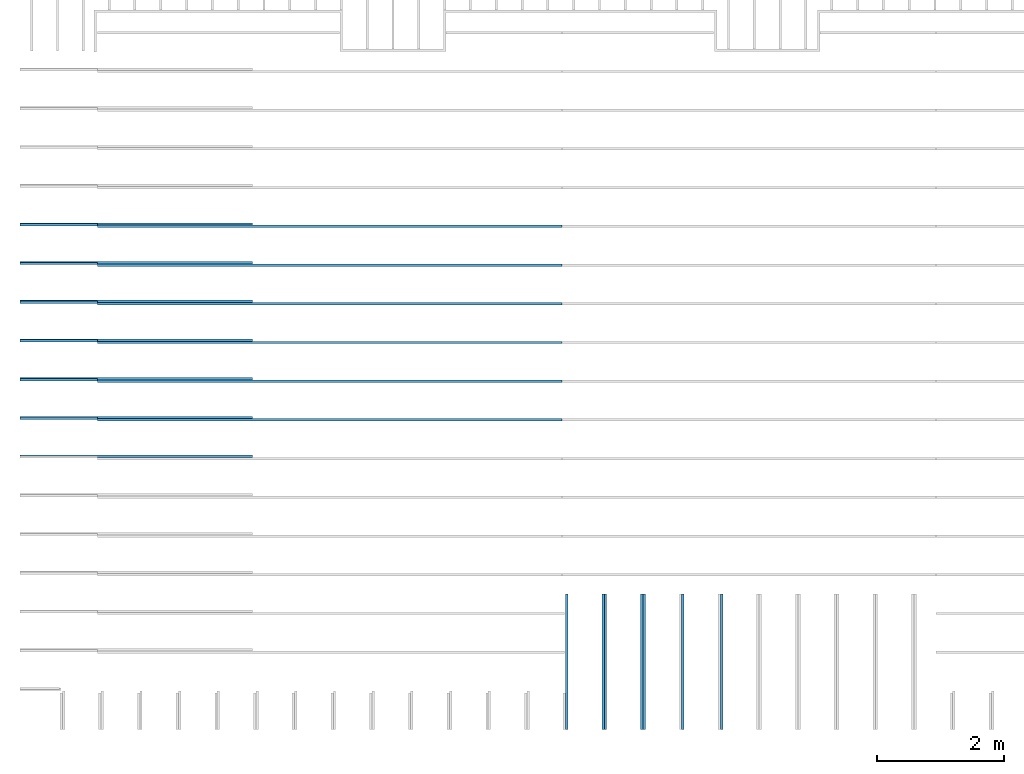
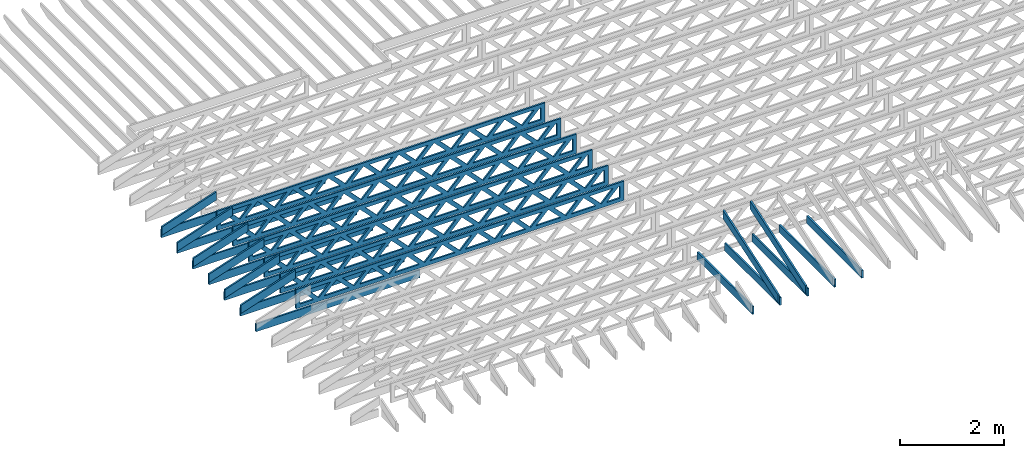
# One storey, part 2 of 17: 26 beams, 5 elements without a shape of their own.
"""IFC4 building model written with IfcOpenShell, lengths in feet."""

from ifc_helpers import new_model, entity, si_unit, converted_unit, derived_unit, direction, frame, frame_2d, origin, origin_2d_with_axis, place, context, subcontext, project, spatial, rectangle, extrude, clip, halfspace, source, transform, mapped, material, material_profile, profile_set, profile_usage, type_object, type_shapes, element, aggregate, save


model = new_model("IFC4")

# Units and contexts
model_context = context("Model", 3, precision=0.0001, world=origin(), true_north=direction((6.12303176911189e-17, 1.0)))
body_context = subcontext(model_context, "Body", "Model", "MODEL_VIEW")
ifc_project = project(units=[converted_unit("LENGTHUNIT", "FOOT", entity("IfcRatioMeasure", 0.3048), si_unit("LENGTHUNIT", "METRE"), dimensions=[1, 0, 0, 0, 0, 0, 0]), converted_unit("AREAUNIT", "SQUARE FOOT", entity("IfcRatioMeasure", 0.09290304), si_unit("AREAUNIT", "SQUARE_METRE"), dimensions=[2, 0, 0, 0, 0, 0, 0]), converted_unit("VOLUMEUNIT", "CUBIC FOOT", entity("IfcRatioMeasure", 0.028316846592), si_unit("VOLUMEUNIT", "CUBIC_METRE"), dimensions=[3, 0, 0, 0, 0, 0, 0]), converted_unit("PLANEANGLEUNIT", "DEGREE", entity("IfcRatioMeasure", 0.0174532925199433), si_unit("PLANEANGLEUNIT", "RADIAN"), dimensions=[0, 0, 0, 0, 0, 0, 0]), si_unit("MASSUNIT", "GRAM", prefix="KILO"), derived_unit("MASSDENSITYUNIT", [(si_unit("MASSUNIT", "GRAM", prefix="KILO"), 1), (si_unit("LENGTHUNIT", "METRE"), -3)]), derived_unit("MOMENTOFINERTIAUNIT", [(si_unit("LENGTHUNIT", "METRE"), 4)]), si_unit("TIMEUNIT", "SECOND"), si_unit("FREQUENCYUNIT", "HERTZ"), si_unit("THERMODYNAMICTEMPERATUREUNIT", "DEGREE_CELSIUS"), derived_unit("THERMALTRANSMITTANCEUNIT", [(si_unit("MASSUNIT", "GRAM", prefix="KILO"), 1), (si_unit("THERMODYNAMICTEMPERATUREUNIT", "KELVIN"), -1), (si_unit("TIMEUNIT", "SECOND"), -3)]), derived_unit("VOLUMETRICFLOWRATEUNIT", [(si_unit("LENGTHUNIT", "METRE"), 3), (si_unit("TIMEUNIT", "SECOND"), -1)]), si_unit("ELECTRICCURRENTUNIT", "AMPERE"), si_unit("ELECTRICVOLTAGEUNIT", "VOLT"), si_unit("POWERUNIT", "WATT"), si_unit("FORCEUNIT", "NEWTON"), si_unit("ILLUMINANCEUNIT", "LUX"), si_unit("LUMINOUSFLUXUNIT", "LUMEN"), si_unit("LUMINOUSINTENSITYUNIT", "CANDELA"), derived_unit("USERDEFINED", [(si_unit("MASSUNIT", "GRAM", prefix="KILO"), -1), (si_unit("LENGTHUNIT", "METRE"), -2), (si_unit("TIMEUNIT", "SECOND"), 3), (si_unit("LUMINOUSFLUXUNIT", "LUMEN"), 1)]), derived_unit("LINEARVELOCITYUNIT", [(si_unit("LENGTHUNIT", "METRE"), 1), (si_unit("TIMEUNIT", "SECOND"), -1)]), si_unit("PRESSUREUNIT", "PASCAL"), derived_unit("USERDEFINED", [(si_unit("LENGTHUNIT", "METRE"), -2), (si_unit("MASSUNIT", "GRAM", prefix="KILO"), 1), (si_unit("TIMEUNIT", "SECOND"), -2)]), derived_unit("LINEARFORCEUNIT", [(si_unit("MASSUNIT", "GRAM", prefix="KILO"), 1), (si_unit("LENGTHUNIT", "METRE"), 1), (si_unit("TIMEUNIT", "SECOND"), -2), (si_unit("LENGTHUNIT", "METRE"), -1)]), derived_unit("PLANARFORCEUNIT", [(si_unit("MASSUNIT", "GRAM", prefix="KILO"), 1), (si_unit("LENGTHUNIT", "METRE"), 1), (si_unit("TIMEUNIT", "SECOND"), -2), (si_unit("LENGTHUNIT", "METRE"), -2)])], contexts=[model_context])

# Site, building, storey
site_placement = place(None, origin())
site = spatial("IfcSite", under=ifc_project, at=site_placement, CompositionType="ELEMENT")
building_placement = place(site_placement, origin())
building = spatial("IfcBuilding", under=site, at=building_placement, CompositionType="ELEMENT")
storey_placement = place(building_placement, frame((0.0, 0.0, 30.4375000000082)))
storey = spatial("IfcBuildingStorey", under=building, at=storey_placement, Name="ROOF", CompositionType="ELEMENT", Elevation=30.4375000000082)

# Assembly, beams
assembly_1_placement = place(storey_placement, origin())
assembly_1 = element("IfcElementAssembly", 1, at=assembly_1_placement, inside=storey, Name="Structural Beam System:Structural Framing System", ObjectType="Structural Beam System:Structural Framing System", AssemblyPlace="NOTDEFINED", PredefinedType="BEAM_GRID")
ifc_material_1 = material(Name="WOOD TRUSS", Category="Materials")
ifc_material_profile_1 = material_profile(ifc_material_1, rectangle(XDim=1.73473973950632, YDim=0.125, at=origin_2d_with_axis()))
ifc_material_profile_2 = material_profile(ifc_material_1, rectangle(XDim=1.73473973950633, YDim=0.125, at=frame_2d((-1.11022302462516e-16, 0.0), x_axis=(1.0, 0.0))))
ifc_material_profile_3 = material_profile(ifc_material_1, rectangle(XDim=1.73473973950632, YDim=0.125, at=origin_2d_with_axis()))
ifc_material_profile_4 = material_profile(ifc_material_1, rectangle(XDim=1.73473973950633, YDim=0.125, at=origin_2d_with_axis()))
ifc_material_profile_5 = material_profile(ifc_material_1, rectangle(XDim=1.73473973950632, YDim=0.125, at=frame_2d((-5.55111512312578e-17, 0.0), x_axis=(1.0, 0.0))))
ifc_material_profile_6 = material_profile(ifc_material_1, rectangle(XDim=1.73473973950633, YDim=0.125, at=frame_2d((-2.77555756156289e-16, 0.0), x_axis=(1.0, 0.0))))
ifc_material_profile_7 = material_profile(ifc_material_1, rectangle(XDim=1.73473973950632, YDim=0.125, at=frame_2d((-4.9960036108132e-16, 0.0), x_axis=(1.0, 0.0))))
ifc_material_profile_8 = material_profile(ifc_material_1, rectangle(XDim=1.73473973950633, YDim=0.125, at=frame_2d((4.44089209850063e-16, 0.0), x_axis=(1.0, 0.0))))
ifc_material_profile_9 = material_profile(ifc_material_1, rectangle(XDim=1.73473973950632, YDim=0.125, at=origin_2d_with_axis()))
ifc_material_profile_10 = material_profile(ifc_material_1, rectangle(XDim=1.73473973950633, YDim=0.125, at=frame_2d((-4.9960036108132e-16, 0.0), x_axis=(1.0, 0.0))))
ifc_material_profile_11 = material_profile(ifc_material_1, rectangle(XDim=0.291666666666664, YDim=0.125, at=frame_2d((-2.77555756156289e-17, 0.0), x_axis=(1.0, 0.0))))
ifc_material_profile_12 = material_profile(ifc_material_1, rectangle(XDim=0.291666666666628, YDim=0.124999999999995, at=frame_2d((-5.55111512312578e-17, 0.0), x_axis=(1.0, 0.0))))
ifc_material_profile_13 = material_profile(ifc_material_1, rectangle(XDim=0.916666666666666, YDim=0.125000000000003, at=frame_2d((-2.77555756156289e-17, 0.0), x_axis=(1.0, 0.0))))
ifc_material_profile_14 = material_profile(ifc_material_1, rectangle(XDim=0.916666666666651, YDim=0.125, at=frame_2d((-2.77555756156289e-17, 0.0), x_axis=(1.0, 0.0))))
ifc_profile_set_1 = profile_set([ifc_material_profile_1, ifc_material_profile_2, ifc_material_profile_3, ifc_material_profile_4, ifc_material_profile_5, ifc_material_profile_6, ifc_material_profile_7, ifc_material_profile_8, ifc_material_profile_9, ifc_material_profile_10, ifc_material_profile_11, ifc_material_profile_12, ifc_material_profile_13, ifc_material_profile_14])
ifc_profile_usage_1 = profile_usage(ifc_profile_set_1, cardinal=8)
beam_type_1 = type_object("IfcBeamType", PredefinedType="BEAM", material=ifc_profile_set_1)
shared_shape_1 = source(origin(), body_context, "Body", "SweptSolid", [
    extrude(rectangle(XDim=1.73473973950632, YDim=0.125, at=frame_2d((8.88178419700125e-16, 0.0), x_axis=(1.0, 0.0))), frame((8.27006284966195, 0.0, 0.101118361020562), z_axis=(0.720569184836762, 0.0, -0.693383046997606), x_axis=(0.693383046997606, 0.0, 0.720569184836762)), (0.0, 0.0, 1.0), 0.291666666666667),
    extrude(rectangle(XDim=1.73473973950633, YDim=0.125, at=frame_2d((4.9960036108132e-16, 0.0), x_axis=(1.0, 0.0))), frame((7.01977697598868, 0.0, -0.101118361020407), z_axis=(0.720569184836758, 0.0, 0.69338304699761), x_axis=(0.69338304699761, 0.0, -0.720569184836758)), (0.0, 0.0, 1.0), 0.291666666666667),
    extrude(rectangle(XDim=1.73473973950632, YDim=0.125, at=origin_2d_with_axis()), frame((5.68672854334628, 0.0, 0.101118361020562), z_axis=(0.720569184836762, 0.0, -0.693383046997606), x_axis=(0.693383046997606, 0.0, 0.720569184836762)), (0.0, 0.0, 1.0), 0.291666666666667),
    extrude(rectangle(XDim=1.73473973950633, YDim=0.125, at=frame_2d((-4.9960036108132e-16, 0.0), x_axis=(1.0, 0.0))), frame((4.43644266967301, 0.0, -0.101118361020407), z_axis=(0.720569184836758, 0.0, 0.69338304699761), x_axis=(0.69338304699761, 0.0, -0.720569184836758)), (0.0, 0.0, 1.0), 0.291666666666667),
    extrude(rectangle(XDim=1.73473973950632, YDim=0.125, at=frame_2d((3.33066907387547e-16, 0.0), x_axis=(1.0, 0.0))), frame((3.10339423703061, 0.0, 0.101118361020562), z_axis=(0.720569184836762, 0.0, -0.693383046997606), x_axis=(0.693383046997606, 0.0, 0.720569184836762)), (0.0, 0.0, 1.0), 0.291666666666667),
    extrude(rectangle(XDim=1.73473973950633, YDim=0.125, at=frame_2d((-1.11022302462516e-16, 0.0), x_axis=(1.0, 0.0))), frame((1.85310836335734, 0.0, -0.101118361020407), z_axis=(0.720569184836758, 0.0, 0.69338304699761), x_axis=(0.69338304699761, 0.0, -0.720569184836758)), (0.0, 0.0, 1.0), 0.291666666666666),
    extrude(rectangle(XDim=1.73473973950632, YDim=0.125, at=frame_2d((5.55111512312578e-17, 0.0), x_axis=(1.0, 0.0))), frame((0.520059930714937, 0.0, 0.101118361020562), z_axis=(0.720569184836762, 0.0, -0.693383046997606), x_axis=(0.693383046997606, 0.0, 0.720569184836762)), (0.0, 0.0, 1.0), 0.291666666666667),
    extrude(rectangle(XDim=1.73473973950633, YDim=0.125, at=origin_2d_with_axis()), frame((-0.730225942958334, 0.0, -0.101118361020407), z_axis=(0.720569184836758, 0.0, 0.69338304699761), x_axis=(0.69338304699761, 0.0, -0.720569184836758)), (0.0, 0.0, 1.0), 0.291666666666666),
    extrude(rectangle(XDim=1.73473973950632, YDim=0.125, at=frame_2d((-5.55111512312578e-17, 0.0), x_axis=(1.0, 0.0))), frame((-2.06327437560074, 0.0, 0.101118361020562), z_axis=(0.720569184836762, 0.0, -0.693383046997606), x_axis=(0.693383046997606, 0.0, 0.720569184836762)), (0.0, 0.0, 1.0), 0.291666666666667),
    extrude(rectangle(XDim=1.73473973950633, YDim=0.125, at=frame_2d((-2.77555756156289e-16, 0.0), x_axis=(1.0, 0.0))), frame((-3.31356024927401, 0.0, -0.101118361020407), z_axis=(0.720569184836758, 0.0, 0.69338304699761), x_axis=(0.69338304699761, 0.0, -0.720569184836758)), (0.0, 0.0, 1.0), 0.291666666666666),
    extrude(rectangle(XDim=1.73473973950632, YDim=0.125, at=origin_2d_with_axis()), frame((-4.64660868191641, 0.0, 0.101118361020562), z_axis=(0.720569184836762, 0.0, -0.693383046997606), x_axis=(0.693383046997606, 0.0, 0.720569184836762)), (0.0, 0.0, 1.0), 0.291666666666667),
    extrude(rectangle(XDim=1.73473973950633, YDim=0.125, at=frame_2d((-4.9960036108132e-16, 0.0), x_axis=(1.0, 0.0))), frame((-5.89689455558968, 0.0, -0.101118361020407), z_axis=(0.720569184836758, 0.0, 0.69338304699761), x_axis=(0.69338304699761, 0.0, -0.720569184836758)), (0.0, 0.0, 1.0), 0.291666666666667),
    extrude(rectangle(XDim=1.73473973950632, YDim=0.125, at=frame_2d((5.55111512312578e-16, 0.0), x_axis=(1.0, 0.0))), frame((-7.22994298823208, 0.0, 0.101118361020562), z_axis=(0.720569184836762, 0.0, -0.693383046997606), x_axis=(0.693383046997606, 0.0, 0.720569184836762)), (0.0, 0.0, 1.0), 0.291666666666667),
    extrude(rectangle(XDim=1.73473973950633, YDim=0.125, at=origin_2d_with_axis()), frame((-8.48022886190535, 0.0, -0.101118361020407), z_axis=(0.720569184836758, 0.0, 0.69338304699761), x_axis=(0.69338304699761, 0.0, -0.720569184836758)), (0.0, 0.0, 1.0), 0.291666666666666),
    extrude(rectangle(XDim=1.73473973950632, YDim=0.125, at=frame_2d((-8.88178419700125e-16, 0.0), x_axis=(1.0, 0.0))), frame((10.8533971559776, 0.0, 0.101118361020503), z_axis=(0.720569184836762, 0.0, -0.693383046997606), x_axis=(0.693383046997606, 0.0, 0.720569184836762)), (0.0, 0.0, 1.0), 0.291666666666664),
    extrude(rectangle(XDim=1.73473973950633, YDim=0.125, at=origin_2d_with_axis()), frame((9.60311128230435, 0.0, -0.101118361020466), z_axis=(0.720569184836758, 0.0, 0.69338304699761), x_axis=(0.69338304699761, 0.0, -0.720569184836758)), (0.0, 0.0, 1.0), 0.291666666666666),
    extrude(rectangle(XDim=1.73473973950632, YDim=0.125, at=frame_2d((8.88178419700125e-16, 0.0), x_axis=(1.0, 0.0))), frame((-9.81327729454775, 0.0, 0.101118361020564), z_axis=(0.720569184836762, 0.0, -0.693383046997606), x_axis=(0.693383046997606, 0.0, 0.720569184836762)), (0.0, 0.0, 1.0), 0.291666666666667),
    extrude(rectangle(XDim=1.73473973950633, YDim=0.125, at=origin_2d_with_axis()), frame((-11.063563168221, 0.0, -0.101118361020405), z_axis=(0.720569184836758, 0.0, 0.69338304699761), x_axis=(0.69338304699761, 0.0, -0.720569184836758)), (0.0, 0.0, 1.0), 0.291666666666666),
    extrude(rectangle(XDim=0.291666666666664, YDim=0.125, at=frame_2d((-2.77555756156289e-17, 0.0), x_axis=(1.0, 0.0))), frame((-12.0000038919293, 0.0, 0.604166666666611), z_axis=(1.0, 0.0, 0.0), x_axis=(0.0, 0.0, -1.0)), (0.0, 0.0, 1.0), 24.0000077838585),
    extrude(rectangle(XDim=0.291666666666628, YDim=0.124999999999995, at=frame_2d((-5.55111512312578e-17, 0.0), x_axis=(1.0, 0.0))), frame((-12.0000038919291, 0.0, -0.604166666666693), z_axis=(1.0, 0.0, 0.0), x_axis=(0.0, 0.0, -1.0)), (0.0, 0.0, 1.0), 24.0000077838583),
    extrude(rectangle(XDim=0.916666666666666, YDim=0.125000000000003, at=frame_2d((-2.77555756156289e-17, 0.0), x_axis=(1.0, 0.0))), frame((11.7083372252626, 0.0, 0.0), z_axis=(1.0, 0.0, 0.0), x_axis=(0.0, 0.0, -1.0)), (0.0, 0.0, 1.0), 0.291666666666687),
    extrude(rectangle(XDim=0.916666666666651, YDim=0.125, at=frame_2d((-2.77555756156289e-17, 0.0), x_axis=(1.0, 0.0))), frame((-12.0000038919293, 0.0, 0.0), z_axis=(1.0, 0.0, 0.0), x_axis=(0.0, 0.0, -1.0)), (0.0, 0.0, 1.0), 0.291666666666687),
])
type_shapes(beam_type_1, [shared_shape_1])
beam_1_placement = place(assembly_1_placement, frame((-253.738164377457, 947.861934882651, 0.74999999999164)))
beam_1 = element("IfcBeam", 2, at=beam_1_placement, type_object=beam_type_1, material=ifc_profile_usage_1, PredefinedType="BEAM", context=body_context, shape_type="MappedRepresentation", body=[
    mapped(shared_shape_1, transform((0.0, 0.0, 0.0), scale=1.0)),
])
ifc_profile_usage_2 = profile_usage(ifc_profile_set_1, cardinal=8)
beam_2_placement = place(assembly_1_placement, frame((-253.738164377457, 945.861934882651, 0.749999999991648)))
beam_2 = element("IfcBeam", 3, at=beam_2_placement, type_object=beam_type_1, material=ifc_profile_usage_2, PredefinedType="BEAM", context=body_context, shape_type="MappedRepresentation", body=[
    mapped(shared_shape_1, transform((0.0, 0.0, 0.0), scale=1.0)),
])
ifc_profile_usage_3 = profile_usage(ifc_profile_set_1, cardinal=8)
beam_3_placement = place(assembly_1_placement, frame((-253.738164377457, 943.861934882651, 0.749999999991651)))
beam_3 = element("IfcBeam", 4, at=beam_3_placement, type_object=beam_type_1, material=ifc_profile_usage_3, PredefinedType="BEAM", context=body_context, shape_type="MappedRepresentation", body=[
    mapped(shared_shape_1, transform((0.0, 0.0, 0.0), scale=1.0)),
])
ifc_profile_usage_4 = profile_usage(ifc_profile_set_1, cardinal=8)
beam_4_placement = place(assembly_1_placement, frame((-253.738164377457, 941.861934882651, 0.749999999991658)))
beam_4 = element("IfcBeam", 5, at=beam_4_placement, type_object=beam_type_1, material=ifc_profile_usage_4, PredefinedType="BEAM", context=body_context, shape_type="MappedRepresentation", body=[
    mapped(shared_shape_1, transform((0.0, 0.0, 0.0), scale=1.0)),
])
ifc_profile_usage_5 = profile_usage(ifc_profile_set_1, cardinal=8)
beam_5_placement = place(assembly_1_placement, frame((-253.738164377457, 939.861934882651, 0.749999999991662)))
beam_5 = element("IfcBeam", 6, at=beam_5_placement, type_object=beam_type_1, material=ifc_profile_usage_5, PredefinedType="BEAM", context=body_context, shape_type="MappedRepresentation", body=[
    mapped(shared_shape_1, transform((0.0, 0.0, 0.0), scale=1.0)),
])
ifc_profile_usage_6 = profile_usage(ifc_profile_set_1, cardinal=8)
beam_6_placement = place(assembly_1_placement, frame((-253.738164377457, 937.861934882651, 0.749999999991669)))
beam_6 = element("IfcBeam", 7, at=beam_6_placement, type_object=beam_type_1, material=ifc_profile_usage_6, PredefinedType="BEAM", context=body_context, shape_type="MappedRepresentation", body=[
    mapped(shared_shape_1, transform((0.0, 0.0, 0.0), scale=1.0)),
])
aggregate(assembly_1, [beam_1, beam_2, beam_3, beam_4, beam_5, beam_6])

assembly_2_placement = place(storey_placement, origin())
assembly_2 = element("IfcElementAssembly", 8, at=assembly_2_placement, inside=storey, Name="Structural Beam System:Structural Framing System", ObjectType="Structural Beam System:Structural Framing System", AssemblyPlace="NOTDEFINED", PredefinedType="BEAM_GRID")
ifc_material_2 = material(Name="BOTTOM CHORD OF FIELD FRAMED OVERHANG", Category="Materials")
ifc_material_profile_15 = material_profile(ifc_material_2, rectangle(XDim=0.604166666666667, YDim=0.125000000000011, at=origin_2d_with_axis()), Name="2X8 - BOTTOM CHORD")
ifc_profile_set_2 = profile_set([ifc_material_profile_15], Name="2X8 - BOTTOM CHORD")
ifc_profile_usage_7 = profile_usage(ifc_profile_set_2, cardinal=8)
beam_type_2 = type_object("IfcBeamType", Name="061100 - Wood Framing:2X8 - BOTTOM CHORD", PredefinedType="BEAM", material=ifc_profile_set_2)
shared_shape_2 = source(origin(), body_context, "Body", "SweptSolid", [
    extrude(rectangle(XDim=0.604166666666667, YDim=0.125000000000011, at=origin_2d_with_axis()), frame((-3.49999999999926, 0.0, 0.0), z_axis=(1.0, 0.0, 0.0), x_axis=(0.0, 0.0, -1.0)), (0.0, 0.0, 1.0), 6.99999999999852),
])
type_shapes(beam_type_2, [shared_shape_2])
beam_7_placement = place(assembly_2_placement, frame((-233.488158437574, 925.36192724029, 1.07291666665406), z_axis=(0.0, 0.0, 1.0), x_axis=(0.0, -1.0, 0.0)))
beam_7 = element("IfcBeam", 9, at=beam_7_placement, type_object=beam_type_2, material=ifc_profile_usage_7, Name="061100 - Wood Framing:2X8 - BOTTOM CHORD", ObjectType="061100 - Wood Framing:2X8 - BOTTOM CHORD", PredefinedType="BEAM", context=body_context, shape_type="MappedRepresentation", body=[
    mapped(shared_shape_2, transform((0.0, 0.0, 0.0), scale=1.0)),
])
ifc_profile_usage_8 = profile_usage(ifc_profile_set_2, cardinal=8)
beam_8_placement = place(assembly_2_placement, frame((-235.488158437574, 925.361926737786, 1.07291666665406), z_axis=(0.0, 0.0, 1.0), x_axis=(0.0, -1.0, 0.0)))
beam_8 = element("IfcBeam", 10, at=beam_8_placement, type_object=beam_type_2, material=ifc_profile_usage_8, Name="061100 - Wood Framing:2X8 - BOTTOM CHORD", ObjectType="061100 - Wood Framing:2X8 - BOTTOM CHORD", PredefinedType="BEAM", context=body_context, shape_type="MappedRepresentation", body=[
    mapped(shared_shape_2, transform((0.0, 0.0, 0.0), scale=1.0)),
])
ifc_profile_usage_9 = profile_usage(ifc_profile_set_2, cardinal=8)
beam_9_placement = place(assembly_2_placement, frame((-237.488158437574, 925.361926235282, 1.07291666665406), z_axis=(0.0, 0.0, 1.0), x_axis=(0.0, -1.0, 0.0)))
beam_9 = element("IfcBeam", 11, at=beam_9_placement, type_object=beam_type_2, material=ifc_profile_usage_9, Name="061100 - Wood Framing:2X8 - BOTTOM CHORD", ObjectType="061100 - Wood Framing:2X8 - BOTTOM CHORD", PredefinedType="BEAM", context=body_context, shape_type="MappedRepresentation", body=[
    mapped(shared_shape_2, transform((0.0, 0.0, 0.0), scale=1.0)),
])
ifc_profile_usage_10 = profile_usage(ifc_profile_set_2, cardinal=8)
beam_10_placement = place(assembly_2_placement, frame((-239.488158437574, 925.361925732779, 1.07291666665406), z_axis=(0.0, 0.0, 1.0), x_axis=(0.0, -1.0, 0.0)))
beam_10 = element("IfcBeam", 12, at=beam_10_placement, type_object=beam_type_2, material=ifc_profile_usage_10, Name="061100 - Wood Framing:2X8 - BOTTOM CHORD", ObjectType="061100 - Wood Framing:2X8 - BOTTOM CHORD", PredefinedType="BEAM", context=body_context, shape_type="MappedRepresentation", body=[
    mapped(shared_shape_2, transform((0.0, 0.0, 0.0), scale=1.0)),
])
ifc_profile_usage_11 = profile_usage(ifc_profile_set_2, cardinal=8)
beam_11_placement = place(assembly_2_placement, frame((-241.488158437574, 925.361925230275, 1.07291666665406), z_axis=(0.0, 0.0, 1.0), x_axis=(0.0, -1.0, 0.0)))
beam_11 = element("IfcBeam", 13, at=beam_11_placement, type_object=beam_type_2, material=ifc_profile_usage_11, Name="061100 - Wood Framing:2X8 - BOTTOM CHORD", ObjectType="061100 - Wood Framing:2X8 - BOTTOM CHORD", PredefinedType="BEAM", context=body_context, shape_type="MappedRepresentation", body=[
    mapped(shared_shape_2, transform((0.0, 0.0, 0.0), scale=1.0)),
])
aggregate(assembly_2, [beam_7, beam_8, beam_9, beam_10, beam_11])

assembly_3_placement = place(storey_placement, origin())
assembly_3 = element("IfcElementAssembly", 14, at=assembly_3_placement, inside=storey, Name="Structural Beam System:Structural Framing System", ObjectType="Structural Beam System:Structural Framing System", AssemblyPlace="NOTDEFINED", PredefinedType="BEAM_GRID")
ifc_material_3 = material(Name="TOP CHORD OF FIELD FRAMED OVERHANG", Category="Materials")
ifc_material_profile_16 = material_profile(ifc_material_3, rectangle(XDim=0.604166666666667, YDim=0.125, at=origin_2d_with_axis()), Name="2X8 TOP CHORD")
ifc_profile_set_3 = profile_set([ifc_material_profile_16], Name="2X8 TOP CHORD")
ifc_profile_usage_12 = profile_usage(ifc_profile_set_3, cardinal=8)
beam_type_3 = type_object("IfcBeamType", Name="Dimension Lumber - Ends:2X8 TOP CHORD", PredefinedType="BEAM", material=ifc_profile_set_3)
shared_shape_3 = source(origin(), body_context, "Body", "Clipping", [
    clip(clip(extrude(rectangle(XDim=0.604166666666667, YDim=0.125, at=origin_2d_with_axis()), frame((-3.68932423085928, 0.0, 0.0), z_axis=(1.0, 0.0, 0.0), x_axis=(0.0, 0.0, -1.0)), (0.0, 0.0, 1.0), 7.57997937023103), halfspace(frame((3.68932423085925, -0.0625000000000025, -0.302083333333339), z_axis=(0.948710608132914, 0.0, -0.316145823973806), x_axis=(0.0, 1.0, 0.0)), False)), halfspace(frame((-3.4879933223468, -0.0625000000000025, 0.302083333333328), z_axis=(-0.948710608132914, 0.0, 0.316145823973805), x_axis=(0.0, 1.0, 0.0)), False)),
])
type_shapes(beam_type_3, [shared_shape_3])
beam_12_placement = place(assembly_3_placement, frame((-237.613158541548, 925.266392269532, 2.43688759934747), z_axis=(0.0, -0.316227766016848, 0.94868329805051), x_axis=(0.0, 0.94868329805051, 0.316227766016848)))
beam_12 = element("IfcBeam", 15, at=beam_12_placement, type_object=beam_type_3, material=ifc_profile_usage_12, Name="Dimension Lumber - Ends:2X8 TOP CHORD", ObjectType="Dimension Lumber - Ends:2X8 TOP CHORD", PredefinedType="BEAM", context=body_context, shape_type="MappedRepresentation", body=[
    mapped(shared_shape_3, transform((0.0, 0.0, 0.0), scale=1.0)),
])
ifc_profile_usage_13 = profile_usage(ifc_profile_set_3, cardinal=8)
beam_13_placement = place(assembly_3_placement, frame((-239.613158541548, 925.266392269532, 2.43688759934747), z_axis=(0.0, -0.316227766016849, 0.94868329805051), x_axis=(0.0, 0.94868329805051, 0.316227766016849)))
beam_13 = element("IfcBeam", 16, at=beam_13_placement, type_object=beam_type_3, material=ifc_profile_usage_13, Name="Dimension Lumber - Ends:2X8 TOP CHORD", ObjectType="Dimension Lumber - Ends:2X8 TOP CHORD", PredefinedType="BEAM", context=body_context, shape_type="MappedRepresentation", body=[
    mapped(shared_shape_3, transform((0.0, 0.0, 0.0), scale=1.0)),
])
aggregate(assembly_3, [beam_12, beam_13])

assembly_4_placement = place(storey_placement, origin())
assembly_4 = element("IfcElementAssembly", 17, at=assembly_4_placement, inside=storey, Name="Structural Beam System:Structural Framing System", ObjectType="Structural Beam System:Structural Framing System", AssemblyPlace="NOTDEFINED", PredefinedType="BEAM_GRID")
ifc_material_4 = material(Name="2X8 TO ROOF", Category="Materials")
ifc_material_profile_17 = material_profile(ifc_material_4, rectangle(XDim=0.604166666666667, YDim=0.125000000000011, at=origin_2d_with_axis()), Name="2X8")
ifc_profile_set_4 = profile_set([ifc_material_profile_17], Name="2X8")
ifc_profile_usage_14 = profile_usage(ifc_profile_set_4, cardinal=8)
beam_type_4 = type_object("IfcBeamType", Name="061100 - Wood Framing:2X8", PredefinedType="BEAM", material=ifc_profile_set_4)
shared_shape_4 = source(origin(), body_context, "Body", "SweptSolid", [
    extrude(rectangle(XDim=0.604166666666667, YDim=0.125000000000011, at=origin_2d_with_axis()), frame((-6.0, 0.0, 0.0), z_axis=(1.0, 0.0, 0.0), x_axis=(0.0, 0.0, -1.0)), (0.0, 0.0, 1.0), 12.000000000033),
])
type_shapes(beam_type_4, [shared_shape_4])
beam_14_placement = place(assembly_4_placement, frame((-263.738193442494, 935.986939927086, 1.07291666665846), z_axis=(0.0, 0.0, 1.0), x_axis=(-1.0, 0.0, 0.0)))
beam_14 = element("IfcBeam", 18, at=beam_14_placement, type_object=beam_type_4, material=ifc_profile_usage_14, Name="061100 - Wood Framing:2X8", ObjectType="061100 - Wood Framing:2X8", PredefinedType="BEAM", context=body_context, shape_type="MappedRepresentation", body=[
    mapped(shared_shape_4, transform((0.0, 0.0, 0.0), scale=1.0)),
])
ifc_profile_usage_15 = profile_usage(ifc_profile_set_4, cardinal=8)
beam_15_placement = place(assembly_4_placement, frame((-263.738178367382, 937.9869399272, 1.07291666665845), z_axis=(0.0, 0.0, 1.0), x_axis=(-1.0, 0.0, 0.0)))
beam_15 = element("IfcBeam", 19, at=beam_15_placement, type_object=beam_type_4, material=ifc_profile_usage_15, Name="061100 - Wood Framing:2X8", ObjectType="061100 - Wood Framing:2X8", PredefinedType="BEAM", context=body_context, shape_type="MappedRepresentation", body=[
    mapped(shared_shape_4, transform((0.0, 0.0, 0.0), scale=1.0)),
])
ifc_profile_usage_16 = profile_usage(ifc_profile_set_4, cardinal=8)
beam_16_placement = place(assembly_4_placement, frame((-263.73816329227, 939.986939927313, 1.07291666665844), z_axis=(0.0, 0.0, 1.0), x_axis=(-1.0, 0.0, 0.0)))
beam_16 = element("IfcBeam", 20, at=beam_16_placement, type_object=beam_type_4, material=ifc_profile_usage_16, Name="061100 - Wood Framing:2X8", ObjectType="061100 - Wood Framing:2X8", PredefinedType="BEAM", context=body_context, shape_type="MappedRepresentation", body=[
    mapped(shared_shape_4, transform((0.0, 0.0, 0.0), scale=1.0)),
])
ifc_profile_usage_17 = profile_usage(ifc_profile_set_4, cardinal=8)
beam_17_placement = place(assembly_4_placement, frame((-263.738148217158, 941.986939927427, 1.07291666665844), z_axis=(0.0, 0.0, 1.0), x_axis=(-1.0, 0.0, 0.0)))
beam_17 = element("IfcBeam", 21, at=beam_17_placement, type_object=beam_type_4, material=ifc_profile_usage_17, Name="061100 - Wood Framing:2X8", ObjectType="061100 - Wood Framing:2X8", PredefinedType="BEAM", context=body_context, shape_type="MappedRepresentation", body=[
    mapped(shared_shape_4, transform((0.0, 0.0, 0.0), scale=1.0)),
])
ifc_profile_usage_18 = profile_usage(ifc_profile_set_4, cardinal=8)
beam_18_placement = place(assembly_4_placement, frame((-263.738133142046, 943.986939927541, 1.07291666665843), z_axis=(0.0, 0.0, 1.0), x_axis=(-1.0, 0.0, 0.0)))
beam_18 = element("IfcBeam", 22, at=beam_18_placement, type_object=beam_type_4, material=ifc_profile_usage_18, Name="061100 - Wood Framing:2X8", ObjectType="061100 - Wood Framing:2X8", PredefinedType="BEAM", context=body_context, shape_type="MappedRepresentation", body=[
    mapped(shared_shape_4, transform((0.0, 0.0, 0.0), scale=1.0)),
])
ifc_profile_usage_19 = profile_usage(ifc_profile_set_4, cardinal=8)
beam_19_placement = place(assembly_4_placement, frame((-263.738118066933, 945.986939927655, 1.07291666665843), z_axis=(0.0, 0.0, 1.0), x_axis=(-1.0, 0.0, 0.0)))
beam_19 = element("IfcBeam", 23, at=beam_19_placement, type_object=beam_type_4, material=ifc_profile_usage_19, Name="061100 - Wood Framing:2X8", ObjectType="061100 - Wood Framing:2X8", PredefinedType="BEAM", context=body_context, shape_type="MappedRepresentation", body=[
    mapped(shared_shape_4, transform((0.0, 0.0, 0.0), scale=1.0)),
])
ifc_profile_usage_20 = profile_usage(ifc_profile_set_4, cardinal=8)
beam_20_placement = place(assembly_4_placement, frame((-263.738102991821, 947.986939927769, 1.07291666665842), z_axis=(0.0, 0.0, 1.0), x_axis=(-1.0, 0.0, 0.0)))
beam_20 = element("IfcBeam", 24, at=beam_20_placement, type_object=beam_type_4, material=ifc_profile_usage_20, Name="061100 - Wood Framing:2X8", ObjectType="061100 - Wood Framing:2X8", PredefinedType="BEAM", context=body_context, shape_type="MappedRepresentation", body=[
    mapped(shared_shape_4, transform((0.0, 0.0, 0.0), scale=1.0)),
])
aggregate(assembly_4, [beam_14, beam_15, beam_16, beam_17, beam_18, beam_19, beam_20])

assembly_5_placement = place(storey_placement, origin())
assembly_5 = element("IfcElementAssembly", 25, at=assembly_5_placement, inside=storey, Name="Structural Beam System:Structural Framing System", ObjectType="Structural Beam System:Structural Framing System", AssemblyPlace="NOTDEFINED", PredefinedType="BEAM_GRID")
ifc_profile_usage_21 = profile_usage(ifc_profile_set_3, cardinal=8)
beam_type_5 = type_object("IfcBeamType", Name="Dimension Lumber - Ends:2X8 TOP CHORD", PredefinedType="BEAM", material=ifc_profile_set_3)
shared_shape_5 = source(origin(), body_context, "Body", "Clipping", [
    clip(clip(extrude(rectangle(XDim=0.604166666666671, YDim=0.125, at=frame_2d((-1.83186799063151e-15, 0.0), x_axis=(1.0, 0.0))), frame((-2.10819527564865, 0.0, 0.0), z_axis=(1.0, 0.0, 0.0), x_axis=(0.0, 0.0, -1.0)), (0.0, 0.0, 1.0), 4.41772145980974), halfspace(frame((2.10819527564862, -0.0625000000000025, -0.302083333333339), z_axis=(0.948710608132914, 0.0, -0.316145823973807), x_axis=(0.0, 1.0, 0.0)), False)), halfspace(frame((-1.90686436713617, -0.0625000000000025, 0.302083333333328), z_axis=(-0.948710608132914, 0.0, 0.316145823973807), x_axis=(0.0, 1.0, 0.0)), False)),
])
type_shapes(beam_type_5, [shared_shape_5])
beam_21_placement = place(assembly_5_placement, frame((-267.833654839365, 937.945265019167, 1.93690371042362), z_axis=(-0.316227766016838, 0.0, 0.948683298050514), x_axis=(0.948683298050514, 0.0, 0.316227766016837)))
beam_21 = element("IfcBeam", 26, at=beam_21_placement, type_object=beam_type_5, material=ifc_profile_usage_21, Name="Dimension Lumber - Ends:2X8 TOP CHORD", ObjectType="Dimension Lumber - Ends:2X8 TOP CHORD", PredefinedType="BEAM", context=body_context, shape_type="MappedRepresentation", body=[
    mapped(shared_shape_5, transform((0.0, 0.0, 0.0), scale=1.0)),
])
ifc_profile_usage_22 = profile_usage(ifc_profile_set_3, cardinal=8)
beam_22_placement = place(assembly_5_placement, frame((-267.833654839365, 939.945265019167, 1.93690371042362), z_axis=(-0.316227766016838, 0.0, 0.948683298050514), x_axis=(0.948683298050514, 0.0, 0.316227766016837)))
beam_22 = element("IfcBeam", 27, at=beam_22_placement, type_object=beam_type_5, material=ifc_profile_usage_22, Name="Dimension Lumber - Ends:2X8 TOP CHORD", ObjectType="Dimension Lumber - Ends:2X8 TOP CHORD", PredefinedType="BEAM", context=body_context, shape_type="MappedRepresentation", body=[
    mapped(shared_shape_5, transform((0.0, 0.0, 0.0), scale=1.0)),
])
ifc_profile_usage_23 = profile_usage(ifc_profile_set_3, cardinal=8)
beam_23_placement = place(assembly_5_placement, frame((-267.833654839365, 941.945265019167, 1.93690371042362), z_axis=(-0.316227766016838, 0.0, 0.948683298050514), x_axis=(0.948683298050514, 0.0, 0.316227766016837)))
beam_23 = element("IfcBeam", 28, at=beam_23_placement, type_object=beam_type_5, material=ifc_profile_usage_23, Name="Dimension Lumber - Ends:2X8 TOP CHORD", ObjectType="Dimension Lumber - Ends:2X8 TOP CHORD", PredefinedType="BEAM", context=body_context, shape_type="MappedRepresentation", body=[
    mapped(shared_shape_5, transform((0.0, 0.0, 0.0), scale=1.0)),
])
ifc_profile_usage_24 = profile_usage(ifc_profile_set_3, cardinal=8)
beam_24_placement = place(assembly_5_placement, frame((-267.833654839365, 943.945265019167, 1.93690371042362), z_axis=(-0.316227766016838, 0.0, 0.948683298050514), x_axis=(0.948683298050514, 0.0, 0.316227766016837)))
beam_24 = element("IfcBeam", 29, at=beam_24_placement, type_object=beam_type_5, material=ifc_profile_usage_24, Name="Dimension Lumber - Ends:2X8 TOP CHORD", ObjectType="Dimension Lumber - Ends:2X8 TOP CHORD", PredefinedType="BEAM", context=body_context, shape_type="MappedRepresentation", body=[
    mapped(shared_shape_5, transform((0.0, 0.0, 0.0), scale=1.0)),
])
ifc_profile_usage_25 = profile_usage(ifc_profile_set_3, cardinal=8)
beam_25_placement = place(assembly_5_placement, frame((-267.833654839365, 945.945265019167, 1.93690371042362), z_axis=(-0.316227766016838, 0.0, 0.948683298050514), x_axis=(0.948683298050514, 0.0, 0.316227766016837)))
beam_25 = element("IfcBeam", 30, at=beam_25_placement, type_object=beam_type_5, material=ifc_profile_usage_25, Name="Dimension Lumber - Ends:2X8 TOP CHORD", ObjectType="Dimension Lumber - Ends:2X8 TOP CHORD", PredefinedType="BEAM", context=body_context, shape_type="MappedRepresentation", body=[
    mapped(shared_shape_5, transform((0.0, 0.0, 0.0), scale=1.0)),
])
ifc_profile_usage_26 = profile_usage(ifc_profile_set_3, cardinal=8)
beam_26_placement = place(assembly_5_placement, frame((-267.833654839365, 947.945265019167, 1.93690371042362), z_axis=(-0.316227766016838, 0.0, 0.948683298050514), x_axis=(0.948683298050514, 0.0, 0.316227766016837)))
beam_26 = element("IfcBeam", 31, at=beam_26_placement, type_object=beam_type_5, material=ifc_profile_usage_26, Name="Dimension Lumber - Ends:2X8 TOP CHORD", ObjectType="Dimension Lumber - Ends:2X8 TOP CHORD", PredefinedType="BEAM", context=body_context, shape_type="MappedRepresentation", body=[
    mapped(shared_shape_5, transform((0.0, 0.0, 0.0), scale=1.0)),
])
aggregate(assembly_5, [beam_21, beam_22, beam_23, beam_24, beam_25, beam_26])

save(model, "model.ifc")
